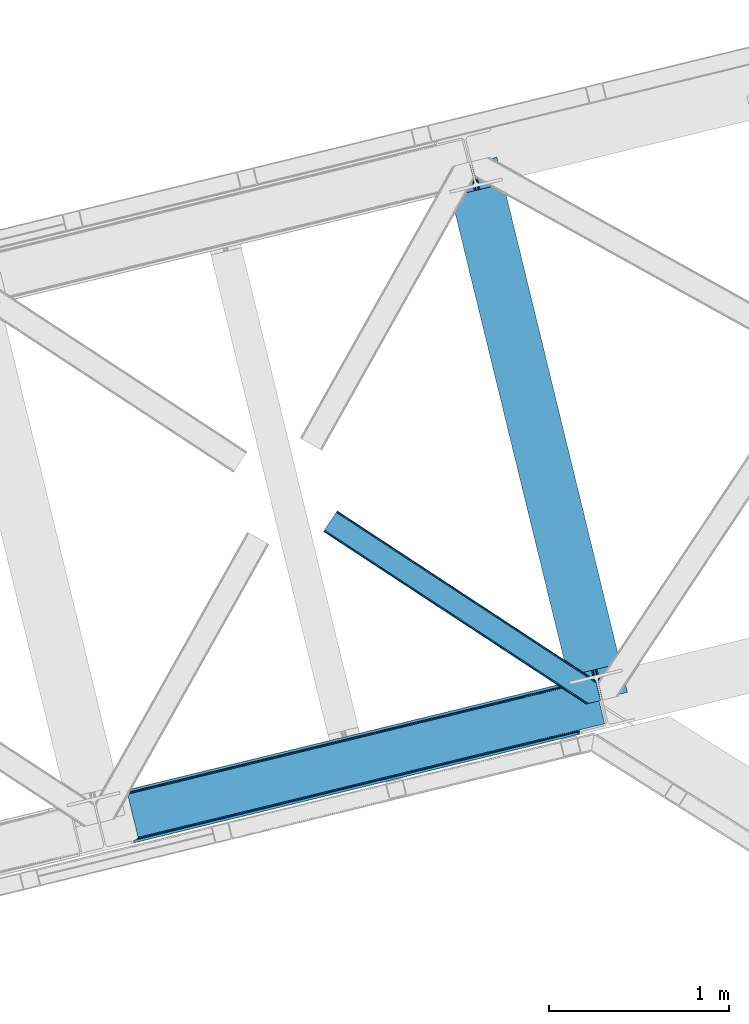
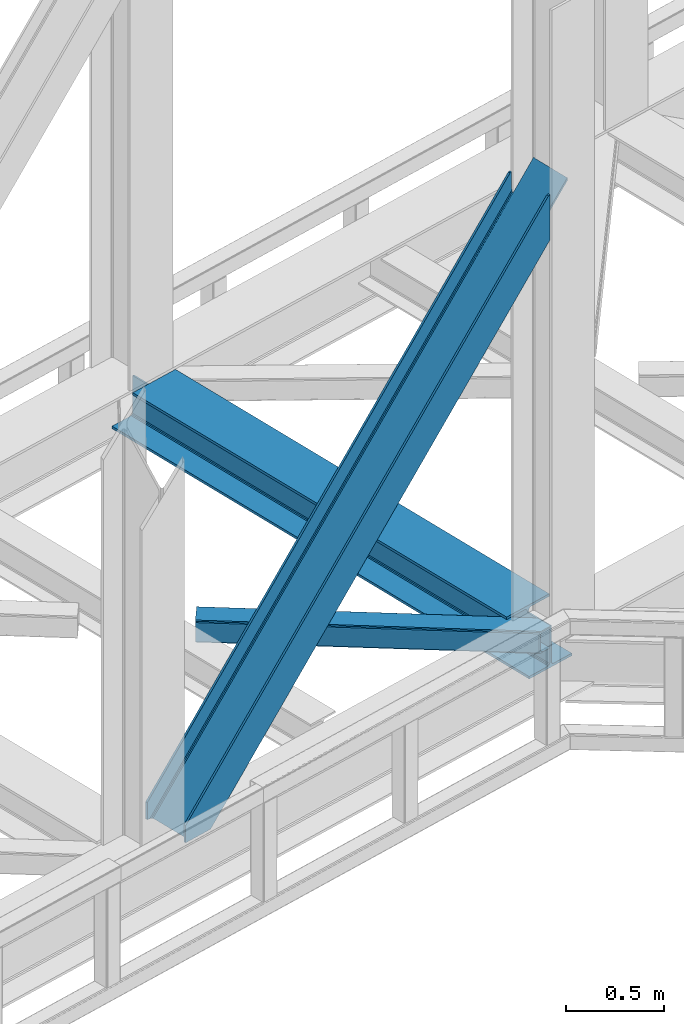
# One storey, part 79 of 93: 2 members, 1 beam.
"""IFC4 building model written with IfcOpenShell, lengths in millimetres."""

from ifc_helpers import new_model, entity, si_unit, converted_unit, derived_unit, direction, frame, origin, place, context, subcontext, project, spatial, triangles, polygons, material, type_object, element, save


model = new_model("IFC4")

# Units and contexts
model_context = context("Model", 3, precision=0.01, world=origin(), true_north=direction((6.12303176911189e-17, 1.0)))
plan_context = context("Plan", 3, precision=0.01, world=origin(), true_north=direction((6.12303176911189e-17, 1.0)))
body_context = subcontext(model_context, "Body", "Model", "MODEL_VIEW")
ifc_project = project(units=[si_unit("LENGTHUNIT", "METRE", prefix="MILLI"), si_unit("AREAUNIT", "SQUARE_METRE"), si_unit("VOLUMEUNIT", "CUBIC_METRE"), converted_unit("PLANEANGLEUNIT", "DEGREE", entity("IfcRatioMeasure", 0.0174532925199433), si_unit("PLANEANGLEUNIT", "RADIAN"), dimensions=[0, 0, 0, 0, 0, 0, 0]), si_unit("MASSUNIT", "GRAM", prefix="KILO"), derived_unit("MASSDENSITYUNIT", [(si_unit("MASSUNIT", "GRAM", prefix="KILO"), 1), (si_unit("LENGTHUNIT", "METRE"), -3)]), derived_unit("MOMENTOFINERTIAUNIT", [(si_unit("LENGTHUNIT", "METRE"), 4)]), si_unit("TIMEUNIT", "SECOND"), si_unit("FREQUENCYUNIT", "HERTZ"), si_unit("THERMODYNAMICTEMPERATUREUNIT", "DEGREE_CELSIUS"), derived_unit("THERMALTRANSMITTANCEUNIT", [(si_unit("MASSUNIT", "GRAM", prefix="KILO"), 1), (si_unit("THERMODYNAMICTEMPERATUREUNIT", "KELVIN"), -1), (si_unit("TIMEUNIT", "SECOND"), -3)]), derived_unit("VOLUMETRICFLOWRATEUNIT", [(si_unit("LENGTHUNIT", "METRE"), 3), (si_unit("TIMEUNIT", "SECOND"), -1)]), derived_unit("MASSFLOWRATEUNIT", [(si_unit("MASSUNIT", "GRAM", prefix="KILO"), 1), (si_unit("TIMEUNIT", "SECOND"), -1)]), derived_unit("ROTATIONALFREQUENCYUNIT", [(si_unit("TIMEUNIT", "SECOND"), -1)]), si_unit("ELECTRICCURRENTUNIT", "AMPERE"), si_unit("ELECTRICVOLTAGEUNIT", "VOLT"), si_unit("POWERUNIT", "WATT"), si_unit("FORCEUNIT", "NEWTON", prefix="KILO"), si_unit("ILLUMINANCEUNIT", "LUX"), si_unit("LUMINOUSFLUXUNIT", "LUMEN"), si_unit("LUMINOUSINTENSITYUNIT", "CANDELA"), derived_unit("USERDEFINED", [(si_unit("MASSUNIT", "GRAM", prefix="KILO"), -1), (si_unit("LENGTHUNIT", "METRE"), -2), (si_unit("TIMEUNIT", "SECOND"), 3), (si_unit("LUMINOUSFLUXUNIT", "LUMEN"), 1)]), derived_unit("LINEARVELOCITYUNIT", [(si_unit("LENGTHUNIT", "METRE"), 1), (si_unit("TIMEUNIT", "SECOND"), -1)]), si_unit("PRESSUREUNIT", "PASCAL"), derived_unit("USERDEFINED", [(si_unit("LENGTHUNIT", "METRE"), -2), (si_unit("MASSUNIT", "GRAM", prefix="KILO"), 1), (si_unit("TIMEUNIT", "SECOND"), -2)]), derived_unit("LINEARFORCEUNIT", [(si_unit("MASSUNIT", "GRAM", prefix="KILO"), 1), (si_unit("LENGTHUNIT", "METRE"), 1), (si_unit("TIMEUNIT", "SECOND"), -2), (si_unit("LENGTHUNIT", "METRE"), -1)]), derived_unit("PLANARFORCEUNIT", [(si_unit("MASSUNIT", "GRAM", prefix="KILO"), 1), (si_unit("LENGTHUNIT", "METRE"), 1), (si_unit("TIMEUNIT", "SECOND"), -2), (si_unit("LENGTHUNIT", "METRE"), -2)])], contexts=[model_context, plan_context])

# Site, building, storey
site_placement = place(None, origin())
site = spatial("IfcSite", under=ifc_project, at=site_placement, CompositionType="ELEMENT")
building_placement = place(site_placement, origin())
building = spatial("IfcBuilding", under=site, at=building_placement, CompositionType="ELEMENT")
storey_placement = place(building_placement, frame((0.0, 0.0, 15900.0)))
storey = spatial("IfcBuildingStorey", under=building, at=storey_placement, CompositionType="ELEMENT", Elevation=15900.0)

# Beam
ifc_material = material(Name="Metal painted (White)")
beam_type = type_object("IfcBeamType", PredefinedType="BEAM")
beam_placement = place(storey_placement, frame((-6288.26277255581, 16262.0986333316, 3385.0)))
element("IfcBeam", 1, at=beam_placement, inside=storey, type_object=beam_type, material=ifc_material, ObjectType="Steel Beam", PredefinedType="BEAM", context=body_context, shape_type="Tessellation", body=[
    polygons([(1018.1664837833, 71.0478278971021, 15.4999999999986), (1018.1664837833, 71.0478278971021, 0.0), (291.465617442446, 3052.25531830421, 0.0), (291.465617442446, 3052.25531830421, 15.4999999999986), (894.779372399328, 40.970914087327, 15.4999999999986), (168.078506058477, 3022.17840449444, 15.4999999999986), (888.08702862538, 39.3395844888265, 16.8701684147941), (161.386162284531, 3020.54707489594, 16.8701684147941), (882.413533524756, 37.956610033654, 20.7720779386456), (155.712667183905, 3019.16410044077, 20.7720779386456), (878.622625296182, 37.0325360459184, 26.6116982174294), (151.921758955332, 3018.24002645303, 26.6116982174294), (877.291435352789, 36.7080444135029, 33.500000000001), (150.590569011938, 3017.91553482062, 33.500000000001), (140.875048430522, 3015.54727389071, 33.500000000001), (140.875048430529, 3015.54727389071, 259.000000000002), (150.590569011936, 3017.91553482062, 259.000000000002), (0.0, 2981.20749040711, 0.0), (3.24860138789518e-12, 2981.20749040711, 15.4999999999986), (123.387111383973, 3011.28440421689, 15.4999999999986), (130.07945515793, 3012.91573381539, 16.8701684147963), (135.752950258543, 3014.29870827056, 20.7720779386413), (139.543858487125, 3015.2227822583, 26.6116982174294), (877.291435352786, 36.7080444135051, 259.000000000002), (867.575914771381, 34.3397834836014, 259.000000000002), (867.575914771373, 34.3397834836014, 33.500000000001), (866.244724827976, 34.0152918511859, 26.6116982174294), (862.453816599394, 33.0912178634502, 20.7720779386413), (856.780321498779, 31.70824340828, 16.8701684147963), (850.087977724824, 30.076913809773, 15.4999999999986), (726.700866340854, 0.0, 15.4999999999986), (726.700866340851, 0.0, 0.0), (838.124523615913, 197.385937999179, 259.069791973884), (186.469722099971, 2870.72539801218, 259.000000000002), (186.693115201822, 2869.8089536072, 259.61730333112), (186.70550404545, 2869.75812937344, 266.500003008253), (837.979344808147, 197.981416001706, 266.500002998871), (837.979694928899, 197.979979696973, 260.000004007589), (828.499586345894, 194.645865944436, 259.006343171919), (828.276216326132, 195.562317481916, 259.61730333112), (828.263827482503, 195.613141715689, 266.500003008253), (176.989986719804, 2867.38985508742, 266.500002998871), (176.989636599053, 2867.39129139215, 260.000004007589), (176.844830940719, 2867.98534020595, 259.07612046749), (176.75420151856, 2868.35713708228, 259.000000000002), (839.310832678078, 198.30468544639, 273.388305639783), (843.101109266765, 199.231350618303, 279.227924098781), (848.774180214308, 200.616065081983, 283.129832400619), (855.466371895431, 202.248018612794, 284.500000377224), (978.853400583268, 232.325271667905, 284.500000138971), (978.851730776622, 232.332121736639, 299.999995328161), (687.386308679347, 161.283492472594, 299.999995890962), (687.387978486002, 161.276642403863, 284.500000701776), (810.77500717385, 191.353895458972, 284.500000463519), (817.467494069993, 192.984637925553, 283.129832461069), (823.141405718744, 194.365903570079, 279.227924137322), (826.932940505748, 195.287407219375, 273.388305663684), (175.658498849865, 2867.06658564273, 273.388305639783), (171.868222261161, 2866.13992047082, 279.227924098781), (166.195151313634, 2864.75520600714, 283.129832400619), (159.502959632503, 2863.12325247633, 284.500000377228), (36.1159309446587, 2833.04599942122, 284.500000138971), (36.117600751305, 2833.03914935249, 299.999995328161), (327.583022848579, 2904.08777861653, 299.999995890962), (327.581353041926, 2904.09462868526, 284.500000701776), (204.194324354083, 2874.01737563015, 284.500000463519), (197.501837457949, 2872.38663316357, 283.129832461069), (191.827925809181, 2871.00536751904, 279.227924137318), (188.036391022195, 2870.08386386975, 273.388305663684)], [[[1, 2, 3, 4]], [[5, 1, 4, 6]], [[7, 5, 6, 8]], [[9, 7, 8, 10]], [[11, 9, 10, 12]], [[13, 11, 12, 14]], [[15, 16, 17, 14, 12, 10, 8, 6, 4, 3, 18, 19, 20, 21, 22, 23]], [[13, 24, 25, 26, 27, 28, 29, 30, 31, 32, 2, 1, 5, 7, 9, 11]], [[2, 32, 18, 3]], [[32, 31, 19, 18]], [[31, 30, 20, 19]], [[27, 26, 15, 23]], [[28, 27, 23, 22]], [[29, 28, 22, 21]], [[30, 29, 21, 20]], [[33, 24, 13, 14, 17, 34, 35, 36, 37, 38]], [[25, 39, 40, 41, 42, 43, 44, 16, 15, 26]], [[39, 25, 24, 33]], [[45, 34, 17, 16]], [[41, 40, 38, 37, 46, 47, 48, 49, 50, 51, 52, 53, 54, 55, 56, 57]], [[42, 58, 59, 60, 61, 62, 63, 64, 65, 66, 67, 68, 69, 36, 35, 43]], [[46, 37, 36, 69]], [[47, 46, 69, 68]], [[48, 47, 68, 67]], [[49, 48, 67, 66]], [[50, 49, 66, 65]], [[51, 50, 65, 64]], [[52, 51, 64, 63]], [[53, 52, 63, 62]], [[54, 53, 62, 61]], [[55, 54, 61, 60]], [[56, 55, 60, 59]], [[57, 56, 59, 58]], [[41, 57, 58, 42]]], closed=False),
])

# Members
member_type_1 = type_object("IfcMemberType", PredefinedType="BRACE")
member_1_placement = place(storey_placement, frame((-8089.65253338993, 15494.8497008549, 3695.0)))
element("IfcMember", 2, at=member_1_placement, inside=storey, type_object=member_type_1, ObjectType="Steel Vertical Brace", PredefinedType="BRACE", context=body_context, shape_type="Tessellation", body=[
    polygons([(1.40772726808791e-11, 286.607857151674, 3.46517481375486e-11), (3.07873920888844, 273.977680395838, 3.46517481375486e-11), (3.07873920887978, 273.977680395836, 106.657658279548), (5.41433564649196e-12, 286.607857151672, 106.657658279548), (2479.77214765692, 877.697901605291, 2779.57626168546), (2490.25200805115, 880.25247845112, 2781.68279398581), (2487.17326884228, 892.882655206959, 2781.68279398581), (2476.69340844805, 890.328078361125, 2779.57626168546), (2487.17326884232, 892.882655206967, 2501.09970740483), (169.685130105999, 327.970402848329, 8.66293703438714e-12), (8.63541989629372, 275.332180101914, 3.0320279620355e-11), (433.383301583627, 378.868970007297, 458.400103479437), (873.798113333203, 486.224739868203, 933.708407497008), (1314.21292508278, 593.58050972911, 1409.01671151459), (1754.62773683235, 700.936279590014, 1884.32501553215), (2195.04254858192, 808.292049450921, 2359.63331954974), (2490.25200805115, 880.25247845112, 2678.23184023267), (2492.62026898092, 870.536957869704, 2654.86848791588), (2492.62026898094, 870.53695786971, 2637.11764726648), (2491.50057367132, 875.130380279155, 2632.19620890634), (2490.57649968358, 878.921288507726, 2623.73498686228), (2490.25200805117, 880.252478451127, 2613.75429494974), (2490.25200805119, 880.252478451131, 2501.09970740482), (2490.57649968356, 878.921288507724, 2668.25114832013), (2491.50057367131, 875.130380279151, 2659.78992627607), (172.763869314872, 315.340226092493, 1.29944055515807e-11), (68.3795180486662, 289.895436106668, 2.16573425859679e-11), (59.456023663077, 286.309951729616, 2.16573425859679e-11), (52.5400336708518, 280.607944959686, 2.16573425859679e-11), (48.6844448546849, 273.657494638771, 2.59888111031614e-11), (48.4762356608549, 266.516743822247, 2.59888111031614e-11), (103.656715327596, 40.145114275335, 2.16573425859679e-11), (107.127583718431, 33.9011775439468, 2.59888111031614e-11), (113.74912144494, 29.5046376636216, 2.16573425859679e-11), (122.513259412632, 27.6248279764103, 2.16573425859679e-11), (132.085737063049, 28.547932466671, 2.16573425859679e-11), (236.47008832926, 53.9927224524939, 1.29944055515807e-11), (239.548827538132, 41.3625456966575, 1.29944055515807e-11), (69.8636974321611, 6.49720277579036e-12, 2.59888111031614e-11), (66.7849582232867, 12.6301767558429, 2.59888111031614e-11), (72.341638910679, 13.9846764619192, 2.59888111031614e-11), (81.2651332962692, 17.5701608389667, 2.59888111031614e-11), (88.1811232884945, 23.2721676088969, 2.16573425859679e-11), (92.0367121046646, 30.2226179298118, 2.16573425859679e-11), (92.2449212984827, 37.3633687463359, 2.16573425859679e-11), (37.0644416317488, 263.734998293248, 2.16573425859679e-11), (33.5935732409145, 269.978935024638, 2.59888111031614e-11), (26.9720355144061, 274.375474904959, 2.59888111031614e-11), (18.2078975467106, 276.255284592173, 2.59888111031614e-11), (2222.97764830487, 815.101525555926, 2325.30413557899), (1786.65153917478, 708.742420216138, 1854.40847676737), (1350.32543004469, 602.383314876352, 1383.51281795575), (913.999320914596, 496.024209536566, 912.617159144125), (477.673211784489, 389.665104196776, 441.721500332495), (904.938963351586, 482.378592516797, 924.094449451842), (905.606971778072, 475.451429015422, 925.040088653682), (469.280862647981, 369.092323675639, 454.144429842066), (468.61285422149, 376.019487177011, 453.198790640217), (1341.26507248168, 588.737697856582, 1394.99010826347), (1341.93308090817, 581.81053435521, 1395.93574746531), (1777.59118161177, 695.09680319637, 1865.88576707508), (1778.25919003826, 688.169639694996, 1866.83140627693), (2213.91729074187, 801.455908536156, 2336.78142588671), (2214.58529916835, 794.528745034784, 2337.72706508856), (906.299295496554, 488.720797624809, 921.401496842536), (469.973186366456, 382.361692285026, 450.505838030915), (1342.62540462664, 595.079902964597, 1392.29715565416), (1778.95151375674, 701.439008304385, 1863.19281446579), (2215.27762288683, 807.798113644168, 2334.08847327741), (909.480869975335, 493.512501104002, 917.371208448875), (473.154760845237, 387.153395764214, 446.475549637249), (1345.80697910543, 599.871606443792, 1388.2668672605), (1782.13308823552, 706.230711783578, 1859.16252607212), (2218.45919736561, 812.589817123363, 2330.05818488374), (2633.7716358821, 903.743176316807, 2789.55036821224), (2635.38992615546, 897.104324888169, 2791.8714949306), (2633.49531741138, 904.876741353294, 2789.15404241362), (878.96554753729, 486.074068413974, 928.954358192258), (438.550735787722, 378.718298553068, 453.646054174687), (1319.38035928687, 593.429838274884, 1404.26266220984), (1759.79517103644, 700.785608135789, 1879.57096622741), (2200.20998278601, 808.141377996695, 2354.87927024499), (883.995269991544, 483.283955436023, 924.924069798597), (443.580458241977, 375.928185575115, 449.615765781021), (1324.41008174112, 590.639725296929, 1400.23237381616), (1764.8248934907, 697.995495157838, 1875.54067783375), (2205.23970524027, 805.351265018742, 2350.84898185132), (888.121551046853, 478.279170342798, 922.231117189295), (447.706739297282, 370.923400481892, 446.92281317172), (1328.53636279643, 585.63494020371, 1397.53942120687), (1768.951174546, 692.990710064611, 1872.84772522445), (2209.36598629557, 800.346479925519, 2348.15602924201), (890.71620181737, 471.821646296262, 921.285477987442), (450.301390067803, 364.465876435356, 445.977173969866), (1331.13101356694, 579.177416157165, 1396.59378200502), (1771.54582531652, 686.53318601807, 1871.9020860226), (2211.96063706608, 793.888955878978, 2347.21039004016), (2635.38992615546, 897.104324888172, 2804.18743054644), (2633.77163588193, 903.743176316768, 2806.50855726461), (2633.49531741138, 904.876741353292, 2806.90488306303), (2692.46501456604, 662.96027887608, 2789.1540424138), (2692.18869609554, 664.093843912616, 2789.55036821219), (2690.57040582217, 670.732695341253, 2791.87149493059), (2690.57040582218, 670.732695341255, 2804.18743054644), (2692.18869609558, 664.093843912622, 2806.50855726476), (2692.46501456604, 662.96027887608, 2806.90488306319), (2269.76577883509, 568.157115487872, 2337.72706508856), (1833.439669705, 461.798010148086, 1866.83140627693), (1397.11356057491, 355.438904808298, 1395.9357474653), (960.787451444811, 249.079799468513, 925.040088653678), (524.461342314724, 142.720694128725, 454.144429842061), (505.481869734545, 138.09424688844, 445.977173969879), (945.89668148413, 245.45001674935, 921.285477987468), (1386.31149323372, 352.805786610262, 1396.59378200506), (1826.72630498331, 460.161556471171, 1871.90208602265), (2267.14111673289, 567.517326332079, 2347.21039004024), (972.538105724893, 234.827377350796, 917.371208448875), (977.70553992898, 234.676705896572, 912.617159144125), (541.379430798871, 128.317600556782, 441.721500332495), (536.211996594793, 128.468272011006, 446.475549637249), (1408.86421485499, 341.186482690586, 1388.2668672605), (1414.03164905907, 341.035811236355, 1383.51281795575), (1845.19032398508, 447.545588030369, 1859.16252607212), (1850.35775818916, 447.394916576143, 1854.40847676737), (2281.51643311517, 553.904693370155, 2330.05818488374), (2286.68386731925, 553.754021915929, 2325.30413557899), (967.50838327064, 237.617490328749, 921.401496842536), (531.182274140543, 131.258384988961, 450.505838030919), (1403.83449240073, 343.976595668537, 1392.29715565416), (1840.16060153083, 450.335701008325, 1863.19281446579), (2276.48671066093, 556.69480634811, 2334.08847327741), (963.382102215336, 242.622275421974, 924.094449451838), (527.055993085239, 136.263170082187, 453.198790640217), (1399.70821134542, 348.981380761758, 1394.99010826347), (1836.03432047551, 455.340486101544, 1865.88576707509), (2272.36042960562, 561.699591441334, 2336.78142588671), (2552.70966144542, 624.027072983099, 2632.19620890634), (2553.63373543315, 620.236164754529, 2623.73498686228), (2553.95822706556, 618.90497481113, 2613.75429494974), (2551.58996613545, 628.620495392468, 2637.11764726648), (946.564689910631, 238.52285324798, 922.231117189325), (506.149878161041, 131.16708338707, 446.922813171728), (1386.97950166022, 345.878623108894, 1397.53942120691), (1827.3943134098, 453.234392969802, 1872.8477252245), (2267.80912515938, 560.590162830712, 2348.15602924209), (945.204357765662, 232.180648139967, 924.924069798623), (504.789546016076, 124.82487827906, 449.61576578103), (1385.61916951524, 339.536418000875, 1400.23237381621), (1826.03398126484, 446.892187861787, 1875.5406778338), (2266.44879301443, 554.247957722706, 2350.8489818514), (942.022783286881, 227.388944660777, 928.954358192284), (501.607971537291, 120.033174799865, 453.6460541747), (1382.43759503646, 334.744714521684, 1404.26266220988), (1822.85240678605, 442.100484382596, 1879.57096622747), (2263.26721853563, 549.456254243506, 2354.87927024505), (937.504332347626, 224.877236228214, 933.708407497034), (497.089520598031, 117.5214663673, 458.40010347945), (1377.91914409721, 332.233006089122, 1409.01671151463), (1818.33395584679, 439.588775950032, 1884.32501553222), (2258.74876759638, 546.944545810944, 2359.6333195498), (2553.95822706554, 618.904974811123, 2678.23184023267), (2553.63373543312, 620.236164754518, 2668.25114832012), (2552.70966144542, 624.027072983099, 2659.78992627607), (2551.58996613546, 628.620495392464, 2654.86848791588), (2553.95822706551, 618.904974811119, 2781.68279398581), (2557.03696627439, 606.274798055283, 2781.68279398581), (2557.03696627445, 606.274798055295, 2501.09970740482), (2553.95822706557, 618.904974811132, 2501.09970740483), (66.784958223264, 12.6301767558364, 106.657658279548), (2543.47836667131, 616.350397965292, 2779.57626168546), (69.8636974321384, 0.0, 106.657658279548), (2546.55710588018, 603.720221209456, 2779.57626168546)], [[[1, 2, 3, 4]], [[5, 6, 7, 8]], [[4, 3, 5, 8]], [[1, 4, 8, 7, 9, 10]], [[3, 2, 11, 12, 13, 14, 15, 16, 17, 6, 5]], [[18, 19, 20, 21, 22, 23, 9, 7, 6, 17, 24, 25]], [[2, 1, 10, 26, 27, 28, 29, 30, 31, 32, 33, 34, 35, 36, 37, 38, 39, 40, 41, 42, 43, 44, 45, 46, 47, 48, 49, 11]], [[10, 9, 23, 26]], [[26, 23, 22, 50, 51, 52, 53, 54, 27]], [[55, 56, 57, 58]], [[59, 60, 56, 55]], [[61, 62, 60, 59]], [[63, 64, 62, 61]], [[65, 55, 58, 66]], [[67, 59, 55, 65]], [[68, 61, 59, 67]], [[69, 63, 61, 68]], [[70, 65, 66, 71]], [[72, 67, 65, 70]], [[73, 68, 67, 72]], [[74, 69, 68, 73]], [[53, 70, 71, 54]], [[52, 72, 70, 53]], [[51, 73, 72, 52]], [[50, 74, 73, 51]], [[64, 75, 76]], [[31, 30, 58, 57]], [[30, 29, 66, 58]], [[29, 28, 71, 66]], [[28, 27, 54, 71]], [[22, 21, 74, 50]], [[21, 20, 69, 74]], [[75, 19, 77]], [[63, 20, 19]], [[20, 63, 69]], [[19, 75, 63]], [[75, 64, 63]], [[78, 13, 12, 79]], [[80, 14, 13, 78]], [[81, 15, 14, 80]], [[82, 16, 15, 81]], [[83, 78, 79, 84]], [[85, 80, 78, 83]], [[86, 81, 80, 85]], [[87, 82, 81, 86]], [[88, 83, 84, 89]], [[90, 85, 83, 88]], [[91, 86, 85, 90]], [[92, 87, 86, 91]], [[93, 88, 89, 94]], [[95, 90, 88, 93]], [[96, 91, 90, 95]], [[97, 92, 91, 96]], [[92, 98, 99]], [[25, 24, 82, 87]], [[24, 17, 16, 82]], [[11, 49, 79, 12]], [[49, 48, 84, 79]], [[48, 47, 89, 84]], [[47, 46, 94, 89]], [[18, 99, 100]], [[87, 18, 25]], [[92, 18, 87]], [[18, 92, 99]], [[98, 92, 97]], [[100, 77, 19, 18]], [[101, 102, 103, 76, 75, 77, 100, 99, 98, 104, 105, 106]], [[31, 57, 56, 60, 62, 64, 76, 103, 107, 108, 109, 110, 111, 32]], [[45, 112, 113, 114, 115, 116, 104, 98, 97, 96, 95, 93, 94, 46]], [[117, 118, 119, 120]], [[121, 122, 118, 117]], [[123, 124, 122, 121]], [[125, 126, 124, 123]], [[127, 117, 120, 128]], [[129, 121, 117, 127]], [[130, 123, 121, 129]], [[131, 125, 123, 130]], [[132, 127, 128, 133]], [[134, 129, 127, 132]], [[135, 130, 129, 134]], [[136, 131, 130, 135]], [[110, 132, 133, 111]], [[109, 134, 132, 110]], [[108, 135, 134, 109]], [[107, 136, 135, 108]], [[107, 102, 136]], [[137, 138, 125, 131]], [[138, 139, 126, 125]], [[36, 35, 120, 119]], [[35, 34, 128, 120]], [[34, 33, 133, 128]], [[33, 32, 111, 133]], [[140, 102, 101]], [[131, 140, 137]], [[136, 140, 131]], [[140, 136, 102]], [[102, 107, 103]], [[141, 113, 112, 142]], [[143, 114, 113, 141]], [[144, 115, 114, 143]], [[145, 116, 115, 144]], [[146, 141, 142, 147]], [[148, 143, 141, 146]], [[149, 144, 143, 148]], [[150, 145, 144, 149]], [[151, 146, 147, 152]], [[153, 148, 146, 151]], [[154, 149, 148, 153]], [[155, 150, 149, 154]], [[156, 151, 152, 157]], [[158, 153, 151, 156]], [[159, 154, 153, 158]], [[160, 155, 154, 159]], [[145, 104, 116]], [[45, 44, 142, 112]], [[44, 43, 147, 142]], [[43, 42, 152, 147]], [[42, 41, 157, 152]], [[161, 162, 155, 160]], [[162, 163, 150, 155]], [[105, 164, 106]], [[150, 164, 145]], [[164, 150, 163]], [[164, 105, 145]], [[104, 145, 105]], [[164, 140, 101, 106]], [[161, 165, 166, 167, 168, 139, 138, 137, 140, 164, 163, 162]], [[36, 119, 118, 122, 124, 126, 139, 168, 37]], [[37, 168, 167, 38]], [[40, 169, 170, 165, 161, 160, 159, 158, 156, 157, 41]], [[171, 39, 38, 167, 166, 172]], [[40, 39, 171, 169]], [[172, 166, 165, 170]], [[169, 171, 172, 170]]], closed=True),
])
member_type_2 = type_object("IfcMemberType", PredefinedType="BRACE")
member_2_placement = place(storey_placement, frame((-6963.31043243408, 16267.696572876, 3510.00011901855)))
element("IfcMember", 3, at=member_2_placement, inside=storey, type_object=member_type_2, ObjectType="Steel Horizontal Brace", PredefinedType="BRACE", context=body_context, shape_type="Tessellation", body=[
    triangles([(1516.36267547607, 132.252392578126, 122.500662231447), (1516.36267547607, 132.252392578126, 17.5000946044929), (76.8296127319336, 1077.23657226563, 122.500662231447), (76.8296127319336, 1077.23657226563, 17.5000946044929), (1516.82485656738, 130.355996704102, 129.197927856447), (76.0959365844728, 1076.12152404785, 129.197927856447), (1518.14163665772, 124.952838134765, 134.874325561526), (74.0158309936523, 1072.95078735352, 134.874325561526), (1520.11244659424, 116.868447875977, 138.667117309571), (70.8979980468748, 1068.20456542969, 138.667117309571), (1522.4373046875, 107.330657958984, 139.999594116212), (67.2267105102537, 1062.60723266602, 139.999594116212), (9.60348358154261, 974.828869628907, 139.999594116212), (1485.96860046387, 5.66825866699219, 139.999594116212), (1543.78367614746, 19.761584472657, 139.999594116212), (1477.07146911621, 3.49978637695313, 138.667117309571), (5.92754516601508, 969.230374145509, 138.667117309571), (1469.52541809082, 1.66036376953161, 134.874325561526), (2.81436309814399, 964.485314941407, 134.874325561526), (1464.48735351562, 0.431369018555415, 129.197927856447), (0.729606628417969, 961.313415527346, 129.197927856447), (1462.71595001221, 0.0, 122.500662231447), (0.0, 960.199530029297, 122.500662231447), (1462.71595001221, 0.0, 17.5000946044929), (0.0, 960.199530029297, 17.5000946044929), (1516.61382293701, 131.222222900391, 12.5201660156272), (1515.01508331299, 131.201293945314, 10.9621215820334), (76.0959365844728, 1076.12152404785, 10.8028289794929), (1387.90133056641, 210.37553100586, 5.21247253418187), (74.0158309936523, 1072.95078735352, 5.12526855468968), (1509.43170318603, 131.129205322266, 5.52059326172093), (1380.44132080078, 208.557037353517, 1.33247680664135), (1371.53953857422, 206.387402343751, 0.0), (70.8979980468748, 1068.20456542969, 1.33247680664135), (67.2267105102537, 1062.60723266602, 0.0), (1375.835206604, 62.7054748535156, 5.51129150390625), (1387.90133056641, 210.37553100586, 5.38222961426072), (1509.43170318603, 131.129205322266, 5.43687744140698), (1342.53491363525, 199.316903686524, 5.39734497070458), (1469.0190536499, 1.53595275878979, 5.55431213379052), (1536.9829284668, 18.1035461425781, 5.53222045898656), (0.729606628417969, 961.313415527346, 10.8028289794929), (2.81436309814399, 964.485314941407, 5.12526855468968), (1375.04339447021, 63.8333129882813, 5.02062377929906), (5.92754516601508, 969.230374145509, 1.33247680664135), (1372.50634002686, 72.1397827148448, 1.33247680664135), (1374.25623321533, 64.9611511230469, 4.52065429687718), (1370.18148193359, 81.6775726318356, 0.0), (9.60348358154261, 974.828869628907, 0.0), (1464.48735351562, 0.431369018555415, 10.8028289794929), (1469.0190536499, 1.53595275878979, 5.52059326172093), (1375.835206604, 62.7054748535156, 5.52059326172093), (1341.56346130371, 199.079708862306, 0.0), (1342.53491363525, 199.316903686524, 5.52059326172093), (1341.56346130371, 199.079708862306, 4.52065429687718), (1520.4391708374, 115.528994750977, 12.5201660156272), (1517.40854187012, 110.267687988282, 8.3320495605476), (1538.42005004883, 18.4535247802742, 6.99957275390625), (1536.9829284668, 18.1035461425781, 5.52059326172093), (1518.10268554687, 101.803088378907, 6.99957275390625), (13.447434997558, 980.682000732422, 6.99957275390625), (63.3827590942383, 1056.7541015625, 6.99957275390625), (1495.27210235596, 7.93556213378906, 6.99957275390625), (67.0586975097658, 1062.3525970459, 8.3320495605476), (70.1718795776369, 1067.09881896973, 12.1260040283232), (1519.2549407959, 120.386837768556, 17.8035644531265), (1518.79217834473, 122.284396362304, 24.4996673583992), (72.2566360473629, 1070.27071838379, 17.8035644531265), (72.9856613159182, 1071.38344116211, 24.4996673583992), (1518.79217834473, 122.284396362304, 115.501089477541), (72.9856613159182, 1071.38344116211, 115.501089477541), (1520.57172088623, 114.984841918946, 127.87475280762), (1519.2549407959, 120.386837768556, 122.196029663086), (1524.86738891602, 97.3626617431637, 133.000021362306), (1522.54253082275, 106.899288940431, 131.667544555665), (1543.78367614746, 19.761584472657, 133.000021362306), (63.3827590942383, 1056.7541015625, 133.000021362306), (67.0586975097658, 1062.3525970459, 131.667544555665), (70.1718795776369, 1067.09881896973, 127.87475280762), (72.2566360473629, 1070.27071838379, 122.196029663086), (13.447434997558, 980.682000732422, 133.000021362306), (1495.27210235596, 7.93556213378906, 133.000021362306), (6.65366363525391, 970.336120605471, 12.1260040283232), (9.77149658203143, 975.082342529297, 8.3320495605476), (3.83988189697266, 966.051498413088, 24.4996673583992), (4.57355804443341, 967.165383911133, 17.8035644531265), (6.65366363525391, 970.336120605471, 127.87475280762), (9.77149658203143, 975.082342529297, 131.667544555665), (3.83988189697266, 966.051498413088, 115.501089477541), (4.57355804443341, 967.165383911133, 122.196029663086), (1478.82891998291, 3.92766723632849, 127.87475280762), (1486.37032012939, 5.76592712402453, 131.667544555665), (1473.78620452881, 2.69867248535229, 122.196029663086), (1472.01480102539, 2.26730346679688, 115.501089477541), (1472.01480102539, 2.26730346679688, 24.4996673583992), (1478.82891998291, 3.92766723632849, 12.1260040283232), (1473.78620452881, 2.69867248535229, 17.8035644531265), (1486.37032012939, 5.76592712402453, 8.3320495605476)], [[1, 2, 3], [4, 3, 2], [5, 1, 6], [3, 6, 1], [7, 5, 8], [6, 8, 5], [9, 7, 10], [8, 10, 7], [11, 9, 12], [10, 12, 9], [13, 11, 12], [11, 13, 14], [15, 11, 14], [16, 14, 13], [13, 17, 16], [18, 16, 17], [17, 19, 18], [20, 18, 19], [19, 21, 20], [22, 20, 21], [21, 23, 22], [24, 22, 25], [23, 25, 22], [4, 26, 27], [4, 2, 26], [28, 27, 29], [29, 30, 28], [27, 31, 29], [30, 29, 32], [32, 33, 34], [35, 34, 33], [32, 34, 30], [27, 28, 4], [36, 37, 38], [37, 36, 39], [38, 40, 36], [41, 40, 38], [42, 43, 44], [43, 45, 46], [46, 47, 43], [47, 44, 43], [48, 46, 45], [45, 49, 48], [50, 24, 42], [25, 42, 24], [51, 50, 52], [42, 52, 50], [53, 35, 33], [49, 53, 48], [53, 49, 35], [33, 54, 53], [29, 33, 32], [53, 54, 55], [29, 54, 33], [48, 55, 47], [48, 53, 55], [47, 46, 48], [56, 31, 27], [57, 31, 56], [27, 26, 56], [58, 59, 60], [60, 31, 57], [31, 60, 59], [61, 60, 62], [60, 61, 63], [58, 60, 63], [64, 57, 56], [65, 56, 66], [66, 67, 68], [69, 68, 67], [66, 68, 65], [56, 65, 64], [60, 57, 62], [64, 62, 57], [67, 70, 71], [71, 69, 67], [72, 7, 9], [7, 72, 73], [74, 75, 11], [75, 72, 9], [76, 74, 15], [11, 15, 74], [75, 9, 11], [26, 66, 56], [2, 1, 67], [67, 66, 2], [26, 2, 66], [1, 70, 67], [73, 5, 7], [1, 5, 73], [70, 1, 73], [75, 74, 77], [77, 78, 75], [72, 75, 78], [78, 79, 72], [73, 72, 79], [79, 80, 73], [70, 73, 80], [80, 71, 70], [81, 74, 82], [81, 77, 74], [74, 76, 82], [28, 65, 68], [69, 3, 4], [28, 68, 4], [28, 30, 65], [68, 69, 4], [65, 30, 34], [62, 35, 49], [35, 64, 34], [64, 35, 62], [64, 65, 34], [6, 79, 8], [71, 3, 69], [3, 80, 6], [80, 3, 71], [6, 80, 79], [12, 77, 13], [10, 8, 79], [79, 78, 10], [78, 77, 12], [12, 10, 78], [83, 45, 43], [49, 61, 62], [49, 84, 61], [84, 49, 45], [83, 84, 45], [85, 25, 23], [42, 86, 83], [43, 42, 83], [86, 42, 25], [85, 86, 25], [17, 87, 19], [13, 77, 81], [81, 88, 13], [88, 87, 17], [17, 13, 88], [21, 19, 87], [23, 89, 85], [90, 23, 21], [23, 90, 89], [90, 21, 87], [91, 92, 16], [18, 91, 16], [93, 18, 20], [93, 22, 94], [18, 93, 91], [22, 93, 20], [92, 14, 16], [15, 82, 76], [15, 14, 82], [92, 82, 14], [22, 95, 94], [51, 96, 97], [97, 95, 24], [24, 95, 22], [97, 50, 51], [50, 97, 24], [59, 63, 51], [63, 98, 51], [98, 96, 51], [59, 58, 63], [93, 94, 90], [89, 90, 94], [91, 93, 87], [90, 87, 93], [92, 91, 88], [87, 88, 91], [82, 92, 81], [88, 81, 92], [94, 95, 85], [85, 89, 94], [98, 63, 61], [61, 84, 98], [96, 98, 84], [84, 83, 96], [97, 96, 83], [83, 86, 97], [95, 97, 86], [86, 85, 95]]),
])

save(model, "model.ifc")
